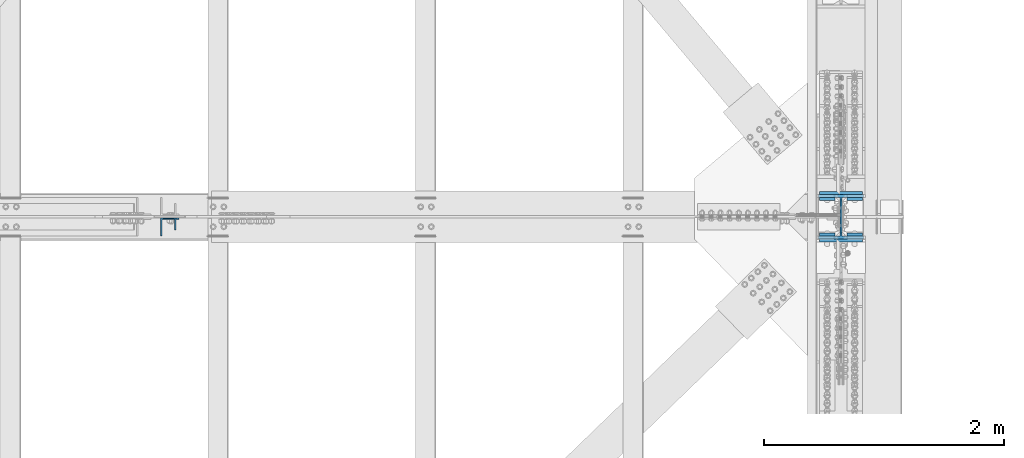
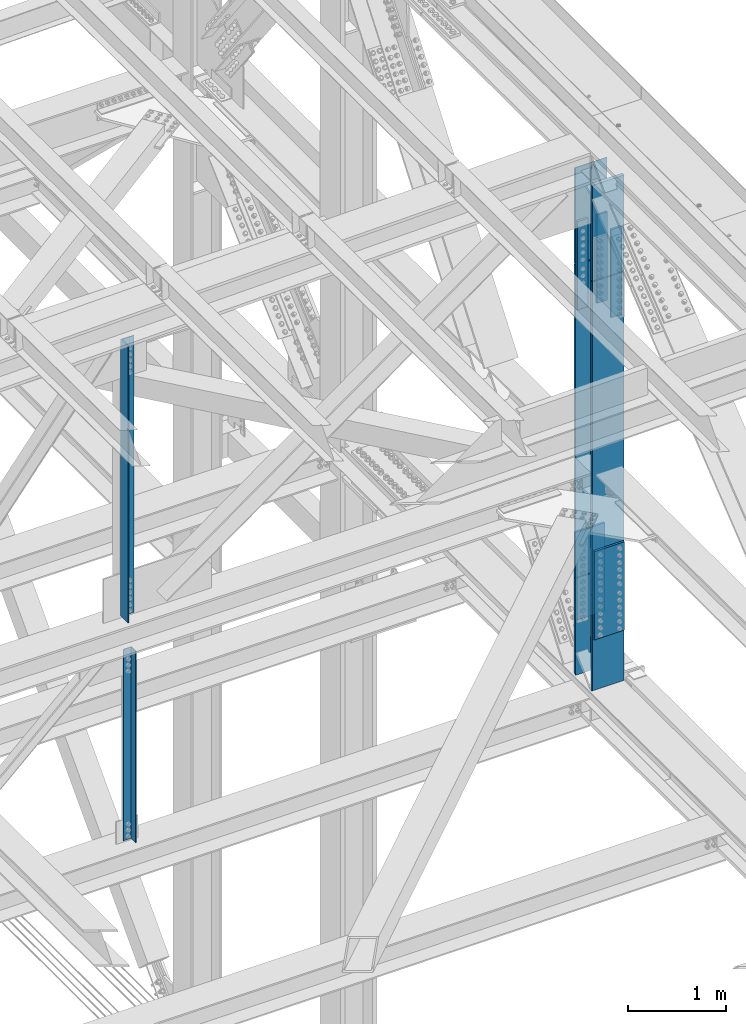
# One storey, part 1421 of 3843: 11 columns, 5 elements without a shape of their own.
"""IFC2X3 building model written with IfcOpenShell, lengths in millimetres."""

from ifc_helpers import new_model, si_unit, frame, origin_with_axes, place, context, subcontext, project, spatial, faceted_brep, material, type_object, element, aggregate, save


model = new_model("IFC2X3")

# Units and contexts
model_context = context("Model", 3, precision=1e-05, world=origin_with_axes())
body_context = subcontext(model_context, "Body", "Model", "MODEL_VIEW")
ifc_project = project(units=[si_unit("LENGTHUNIT", "METRE", prefix="MILLI"), si_unit("AREAUNIT", "SQUARE_METRE"), si_unit("VOLUMEUNIT", "CUBIC_METRE"), si_unit("MASSUNIT", "GRAM", prefix="KILO"), si_unit("TIMEUNIT", "SECOND"), si_unit("PLANEANGLEUNIT", "RADIAN"), si_unit("SOLIDANGLEUNIT", "STERADIAN"), si_unit("THERMODYNAMICTEMPERATUREUNIT", "DEGREE_CELSIUS"), si_unit("LUMINOUSINTENSITYUNIT", "LUMEN")], contexts=[model_context])

# Site, building, storey
site_placement = place(None, origin_with_axes())
site = spatial("IfcSite", under=ifc_project, at=site_placement, CompositionType="ELEMENT")
building_placement = place(site_placement, origin_with_axes())
building = spatial("IfcBuilding", under=site, at=building_placement, Name="Undefined", CompositionType="ELEMENT")
storey_placement = place(building_placement, origin_with_axes())
storey = spatial("IfcBuildingStorey", under=building, at=storey_placement, Name="Undefined", CompositionType="ELEMENT", Elevation=0.0)

# Assembly, column
assembly_1_placement = place(storey_placement, origin_with_axes())
assembly_1 = element("IfcElementAssembly", 1, at=assembly_1_placement, inside=storey, Name="ANGLE", AssemblyPlace="NOTDEFINED", PredefinedType="RIGID_FRAME")
ifc_material_1 = material(Name="STEEL/A572-50")
column_type_1 = type_object("IfcColumnType", Name="L4X4X3/8", PredefinedType="NOTDEFINED")
column_1_placement = place(assembly_1_placement, frame((80060.7999999579, 83924.775, 39453.3460223214), z_axis=(-1.0, 0.0, 0.0), x_axis=(0.0, 0.0, 1.0)))
column_1 = element("IfcColumn", 2, at=column_1_placement, type_object=column_type_1, material=ifc_material_1, Name="ANGLE", ObjectType="L4X4X3/8", context=body_context, shape_type="Brep", body=[
    faceted_brep([(204.712264354988, 50.8000000000029, -50.8000000000029), (204.712264354988, 50.8000000000029, 50.8000000000029), (2598.56616660072, 50.8000000000029, 50.8000000000029), (2598.56616660072, 50.8000000000029, -50.8000000000029), (204.712264354988, 41.2749999999942, 50.8000000000029), (2598.56616660072, 41.2749999999942, 50.8000000000029), (204.712264354988, 41.2749999999942, -41.2749999999942), (2598.56616660072, 41.2749999999942, -41.2749999999942), (204.712264354988, -50.8000000000029, -41.2749999999942), (2598.56616660072, -50.8000000000029, -41.2749999999942), (204.712264354988, -50.8000000000029, -50.8000000000029), (2598.56616660072, -50.8000000000029, -50.8000000000029)], [[[0, 1, 2, 3]], [[1, 4, 5, 2]], [[4, 6, 7, 5]], [[6, 8, 9, 7]], [[8, 10, 11, 9]], [[10, 0, 3, 11]], [[5, 7, 9, 11, 3, 2]], [[10, 8, 6, 4, 1, 0]]]),
])
aggregate(assembly_1, [column_1])

# Assembly, columns
assembly_2_placement = place(storey_placement, origin_with_axes())
assembly_2 = element("IfcElementAssembly", 3, at=assembly_2_placement, inside=storey, Name="BEAM", AssemblyPlace="NOTDEFINED", PredefinedType="RIGID_FRAME")
column_type_2 = type_object("IfcColumnType", PredefinedType="NOTDEFINED")
column_2_placement = place(assembly_2_placement, frame((85534.5, 83837.4625000118, 44292.6980310956), z_axis=(1.0, 0.0, 0.0), x_axis=(0.0, 0.0, 1.0)))
column_2 = element("IfcColumn", 4, at=column_2_placement, type_object=column_type_2, material=ifc_material_1, Name="PLATE", context=body_context, shape_type="Brep", body=[
    faceted_brep([(-4.36557456851006e-11, 12.7000000000116, -63.5), (-4.36557456851006e-11, 12.7000000000116, 63.5), (1104.90000001677, 12.7000000017251, 63.5), (1104.90000001677, 12.7000000017251, -63.5), (1.45519152283669e-11, -12.700000000008, 63.5), (1104.90000001682, -12.6999999982909, 63.5), (1.45519152283669e-11, -12.700000000008, -63.5), (1104.90000001682, -12.6999999982909, -63.5)], [[[0, 1, 2, 3]], [[1, 4, 5, 2]], [[4, 6, 7, 5]], [[6, 0, 3, 7]], [[5, 7, 3, 2]], [[6, 4, 1, 0]]]),
])
column_3_placement = place(assembly_2_placement, frame((85534.5, 84132.7375000003, 44292.6980310956), z_axis=(1.0, 0.0, 0.0), x_axis=(0.0, 0.0, 1.0)))
column_3 = element("IfcColumn", 5, at=column_3_placement, type_object=column_type_2, material=ifc_material_1, Name="PLATE", context=body_context, shape_type="Brep", body=[
    faceted_brep([(-4.36557456851006e-11, 12.7000000000116, -63.5), (-4.36557456851006e-11, 12.7000000000116, 63.5), (1104.90000001677, 12.7000000017251, 63.5), (1104.90000001677, 12.7000000017251, -63.5), (1.45519152283669e-11, -12.700000000008, 63.5), (1104.90000001682, -12.6999999982909, 63.5), (1.45519152283669e-11, -12.700000000008, -63.5), (1104.90000001682, -12.6999999982909, -63.5)], [[[0, 1, 2, 3]], [[1, 4, 5, 2]], [[4, 6, 7, 5]], [[6, 0, 3, 7]], [[5, 7, 3, 2]], [[6, 4, 1, 0]]]),
])
column_4_placement = place(assembly_2_placement, frame((85763.1, 83837.4625000118, 44292.6980310956), z_axis=(1.0, 0.0, 0.0), x_axis=(0.0, 0.0, 1.0)))
column_4 = element("IfcColumn", 6, at=column_4_placement, type_object=column_type_2, material=ifc_material_1, Name="PLATE", context=body_context, shape_type="Brep", body=[
    faceted_brep([(-4.36557456851006e-11, 12.7000000000116, -63.5), (-4.36557456851006e-11, 12.7000000000116, 63.5), (1104.90000001677, 12.7000000017251, 63.5), (1104.90000001677, 12.7000000017251, -63.5), (1.45519152283669e-11, -12.700000000008, 63.5), (1104.90000001682, -12.6999999982909, 63.5), (1.45519152283669e-11, -12.700000000008, -63.5), (1104.90000001682, -12.6999999982909, -63.5)], [[[0, 1, 2, 3]], [[1, 4, 5, 2]], [[4, 6, 7, 5]], [[6, 0, 3, 7]], [[5, 7, 3, 2]], [[6, 4, 1, 0]]]),
])
column_5_placement = place(assembly_2_placement, frame((85763.1, 84132.7375000003, 44292.6980310956), z_axis=(1.0, 0.0, 0.0), x_axis=(0.0, 0.0, 1.0)))
column_5 = element("IfcColumn", 7, at=column_5_placement, type_object=column_type_2, material=ifc_material_1, Name="PLATE", context=body_context, shape_type="Brep", body=[
    faceted_brep([(-4.36557456851006e-11, 12.7000000000116, -63.5), (-4.36557456851006e-11, 12.7000000000116, 63.5), (1104.90000001677, 12.7000000017251, 63.5), (1104.90000001677, 12.7000000017251, -63.5), (1.45519152283669e-11, -12.700000000008, 63.5), (1104.90000001682, -12.6999999982909, 63.5), (1.45519152283669e-11, -12.700000000008, -63.5), (1104.90000001682, -12.6999999982909, -63.5)], [[[0, 1, 2, 3]], [[1, 4, 5, 2]], [[4, 6, 7, 5]], [[6, 0, 3, 7]], [[5, 7, 3, 2]], [[6, 4, 1, 0]]]),
])

# Assembly, column
assembly_3_placement = place(storey_placement, origin_with_axes())
assembly_3 = element("IfcElementAssembly", 8, at=assembly_3_placement, inside=storey, Name="ANGLE", AssemblyPlace="NOTDEFINED", PredefinedType="RIGID_FRAME")
column_type_3 = type_object("IfcColumnType", Name="L6X6X1/2", PredefinedType="NOTDEFINED")
column_6_placement = place(assembly_3_placement, frame((80060.8, 83899.375, 42311.5808310413), z_axis=(0.0, -1.0, 0.0), x_axis=(0.0, 0.0, 1.0)))
column_6 = element("IfcColumn", 9, at=column_6_placement, type_object=column_type_3, material=ifc_material_1, Name="ANGLE", ObjectType="L6X6X1/2", context=body_context, shape_type="Brep", body=[
    faceted_brep([(165.415434551687, 76.1999999999971, -76.1999999999971), (165.415434551687, 76.1999999999971, 76.1999999999971), (3626.66987168015, 76.1999999999971, 76.1999999999971), (3626.66987168015, 76.1999999999971, -76.1999999999971), (165.415434551687, 63.5, 76.1999999999971), (3626.66987168015, 63.5, 76.1999999999971), (165.415434551687, 63.5, -63.5), (3626.66987168015, 63.5, -63.5), (165.415434551687, -76.1999999999971, -63.5), (3626.66987168015, -76.1999999999971, -63.5), (165.415434551687, -76.1999999999971, -76.1999999999971), (3626.66987168015, -76.1999999999971, -76.1999999999971)], [[[0, 1, 2, 3]], [[1, 4, 5, 2]], [[4, 6, 7, 5]], [[6, 8, 9, 7]], [[8, 10, 11, 9]], [[10, 0, 3, 11]], [[5, 7, 9, 11, 3, 2]], [[10, 8, 6, 4, 1, 0]]]),
])
aggregate(assembly_3, [column_6])

# Assembly, columns
assembly_4_placement = place(storey_placement, origin_with_axes())
assembly_4 = element("IfcElementAssembly", 10, at=assembly_4_placement, inside=storey, Name="BEAM", AssemblyPlace="NOTDEFINED", PredefinedType="RIGID_FRAME")
column_type_4 = type_object("IfcColumnType", PredefinedType="NOTDEFINED")
column_7_placement = place(assembly_4_placement, frame((85648.8, 83786.6620684038, 40374.7131606744), z_axis=(-1.0, 0.0, 0.0), x_axis=(0.0, 0.0, 1.0)))
column_7 = element("IfcColumn", 11, at=column_7_placement, type_object=column_type_4, material=ifc_material_1, Name="PLATE", context=body_context, shape_type="Brep", body=[
    faceted_brep([(-1.45519152283669e-11, 12.7000000000025, -177.800000000003), (-1.45519152283669e-11, 12.7000000000025, 177.800000000003), (1104.90000001682, 12.7000000017051, 177.800000000003), (1104.90000001682, 12.7000000017051, -177.800000000003), (4.36557456851006e-11, -12.7000000000171, 177.800000000003), (1104.90000001686, -12.6999999983072, 177.800000000003), (4.36557456851006e-11, -12.7000000000171, -177.800000000003), (1104.90000001686, -12.6999999983072, -177.800000000003)], [[[0, 1, 2, 3]], [[1, 4, 5, 2]], [[4, 6, 7, 5]], [[6, 0, 3, 7]], [[5, 7, 3, 2]], [[6, 4, 1, 0]]]),
])
column_8_placement = place(assembly_4_placement, frame((85648.8, 84183.5375848503, 40374.7131221762), z_axis=(-1.0, 0.0, 0.0), x_axis=(0.0, 0.0, 1.0)))
column_8 = element("IfcColumn", 12, at=column_8_placement, type_object=column_type_4, material=ifc_material_1, Name="PLATE", context=body_context, shape_type="Brep", body=[
    faceted_brep([(-1.45519152283669e-11, 12.7000000000025, -177.800000000003), (-1.45519152283669e-11, 12.7000000000025, 177.800000000003), (1104.90000001682, 12.7000000017051, 177.800000000003), (1104.90000001682, 12.7000000017051, -177.800000000003), (4.36557456851006e-11, -12.7000000000171, 177.800000000003), (1104.90000001686, -12.6999999983072, 177.800000000003), (4.36557456851006e-11, -12.7000000000171, -177.800000000003), (1104.90000001686, -12.6999999983072, -177.800000000003)], [[[0, 1, 2, 3]], [[1, 4, 5, 2]], [[4, 6, 7, 5]], [[6, 0, 3, 7]], [[5, 7, 3, 2]], [[6, 4, 1, 0]]]),
])

# Column
ifc_material_2 = material(Name="STEEL/A992")
column_type_5 = type_object("IfcColumnType", Name="W14X132", PredefinedType="NOTDEFINED")
column_9_placement = place(assembly_2_placement, frame((85648.8, 83985.1000000118, 44845.1480310956), z_axis=(0.0, 1.0, 0.0), x_axis=(0.0, 0.0, 1.0)))
column_9 = element("IfcColumn", 13, at=column_9_placement, type_object=column_type_5, material=ifc_material_2, Name="COLUMN", ObjectType="W14X132", context=body_context, shape_type="Brep", body=[
    faceted_brep([(1203.49614586103, 7.9375, -131.830367742543), (1203.16005296064, 7.9375, 131.820908106049), (1215.47494978287, -4.38226544305508, 131.826701123922), (1215.60898224003, -4.17675526843232, -131.83396684844), (1160.79769559304, -7.9375, -131.817680686072), (1160.79769559304, 7.9375, -131.817680686072), (1215.60898224003, -7.9375, -131.83396684844), (1155.61559319846, -7.9375, -133.34888497577), (1155.61559319846, 7.9375, -133.34888497577), (1152.10036716526, -7.9375, -137.452780410618), (1152.10036716526, 7.9375, -137.452780410618), (1151.38334385253, -7.9375, -142.80858561369), (1151.38334385253, 7.9375, -142.80858561369), (1153.69528719012, -7.9375, -147.692609549733), (1153.69528719012, 7.9375, -147.692609549733), (1165.03467557713, -7.9375, -160.337499999994), (1165.03467557713, 7.9375, -160.337499999994), (1215.64334699394, -7.9375, -160.337499999994), (1215.64334699394, 7.9375, -160.337499999994), (1165.03467557713, 187.324999999997, -160.337499999994), (6.34999999999854, 187.324999999997, -160.337499999994), (6.34999999999854, 7.9375, -160.337499999994), (1215.64334699394, 187.324999999997, -160.337499999994), (6.34999999999854, 7.9375, 160.337499999994), (1164.81580677307, 7.9375, 160.337499999994), (1153.45887069991, 7.9375, 147.676054499054), (1151.14667432922, 7.9375, 142.79162139204), (1151.86398828181, 7.9375, 137.435372748922), (1155.37991423679, 7.9375, 133.331447370423), (1160.56270033512, 7.9375, 131.800869998217), (1153.45887069991, -7.9375, 147.676054499054), (1164.81580677307, -7.9375, 160.337499999994), (1151.14667432922, -7.9375, 142.79162139204), (1151.86398828181, -7.9375, 137.435372748922), (1155.37991423679, -7.9375, 133.331447370423), (1160.56270033512, -7.9375, 131.800869998217), (1215.47494978287, -7.9375, 131.826701123922), (6.34999999999854, -7.9375, 160.337499999994), (6.34999999999854, -7.9375, -160.337499999994), (6.34999999999854, -187.324999999997, -160.337499999994), (1165.03467557713, -187.324999999997, -160.337499999994), (1215.64334699394, -187.324999999997, -160.337499999994), (6.34999999999854, -187.324999999997, -185.737500000003), (6.34999999999854, 187.324999999997, -185.737500000003), (1201.58013327211, 187.324999999997, -185.737500000003), (1201.58013327211, -187.324999999997, -185.737500000003), (1215.64395755383, 187.324999999997, -161.355846424747), (1215.64395755383, -187.324999999997, -161.355846424747), (6.34999999999854, -187.324999999997, 160.337499999994), (6.34999999999854, -187.324999999997, 185.737500000003), (6.34999999999854, 187.324999999997, 185.737500000003), (6.34999999999854, 187.324999999997, 160.337499999994), (1201.29530060472, -187.324999999997, 185.737500000003), (1201.29530060472, 187.324999999997, 185.737500000003), (1215.45017650162, -187.324999999997, 160.974301780676), (1215.45017650162, 187.324999999997, 160.974301780676), (1164.81580677307, 187.324999999997, 160.337499999994), (1215.45051996414, 187.324999999997, 160.337499999994), (1215.45051996414, 7.9375, 160.402995546756), (1215.45051996414, -7.9375, 160.402995546756), (1164.81580677307, -187.324999999997, 160.337499999994), (1215.45051996414, -187.324999999997, 160.337499999994)], [[[0, 1, 2, 3]], [[4, 5, 0, 3, 6]], [[7, 8, 5, 4]], [[9, 10, 8, 7]], [[11, 12, 10, 9]], [[13, 14, 12, 11]], [[15, 16, 14, 13]], [[16, 15, 17, 18]], [[19, 20, 21, 16, 18, 22]], [[0, 5, 8, 10, 12, 14, 16, 21, 23, 24, 25, 26, 27, 28, 29, 1]], [[30, 25, 24, 31]], [[32, 26, 25, 30]], [[33, 27, 26, 32]], [[34, 28, 27, 33]], [[35, 29, 28, 34]], [[1, 29, 35, 36, 2]], [[3, 2, 36, 6]], [[35, 34, 33, 32, 30, 31, 37, 38, 15, 13, 11, 9, 7, 4, 6, 36]], [[15, 38, 39, 40, 41, 17]], [[42, 43, 44, 45]], [[45, 44, 46, 47]], [[40, 39, 42, 45, 47, 41]], [[46, 22, 18, 17, 41, 47]], [[44, 43, 20, 19, 22, 46]], [[42, 39, 38, 37, 48, 49, 50, 51, 23, 21, 20, 43]], [[50, 49, 52, 53]], [[53, 52, 54, 55]], [[56, 51, 50, 53, 55, 57]], [[24, 23, 51, 56, 57, 58]], [[31, 24, 58, 59]], [[60, 48, 37, 31, 59, 61]], [[52, 49, 48, 60, 61, 54]], [[59, 58, 57, 55, 54, 61]]]),
])

aggregate(assembly_2, [column_2, column_3, column_4, column_5, column_9])

# Assembly, column
assembly_5_placement = place(storey_placement, origin_with_axes())
assembly_5 = element("IfcElementAssembly", 14, at=assembly_5_placement, inside=storey, Name="COLUMN", AssemblyPlace="NOTDEFINED", PredefinedType="RIGID_FRAME")
column_10_placement = place(assembly_5_placement, frame((85648.8, 83985.1001383307, 40927.1631414253), z_axis=(0.0, 1.0, 0.0), x_axis=(0.0, 0.0, 1.0)))
column_10 = element("IfcColumn", 15, at=column_10_placement, type_object=column_type_5, material=ifc_material_2, Name="COLUMN", ObjectType="W14X132", context=body_context, shape_type="Brep", body=[
    faceted_brep([(6.34999999999854, 187.324999999997, -185.737500000003), (6.34999999999854, 187.324999999997, -160.337499999994), (3911.6348952821, 187.324999999997, -160.337499989633), (3911.6348961711, 187.324999999997, -185.737499989642), (6.34999999999854, 7.9375, -160.337499999994), (3911.6348952821, 7.9375, -160.337499989633), (6.34999999999854, 7.9375, 160.337499999994), (3911.63488405848, 7.9375, 160.33750001037), (6.34999999999854, 187.324999999997, 160.337499999994), (3911.63488405848, 187.324999999997, 160.33750001037), (6.34999999999854, 187.324999999997, 185.737500000003), (3911.63488316947, 187.324999999997, 185.737500010364), (6.34999999999854, -187.324999999997, 185.737500000003), (3911.63488316947, -187.324999999997, 185.737500010364), (6.34999999999854, -187.324999999997, 160.337499999994), (3911.63488405848, -187.324999999997, 160.33750001037), (6.34999999999854, -7.9375, 160.337499999994), (3911.63488405848, -7.9375, 160.33750001037), (6.34999999999854, -7.9375, -160.337499999994), (3911.6348952821, -7.9375, -160.337499989633), (6.34999999999854, -187.324999999997, -160.337499999994), (3911.6348952821, -187.324999999997, -160.337499989633), (6.34999999999854, -187.324999999997, -185.737500000003), (3911.6348961711, -187.324999999997, -185.737499989642)], [[[0, 1, 2, 3]], [[1, 4, 5, 2]], [[4, 6, 7, 5]], [[6, 8, 9, 7]], [[8, 10, 11, 9]], [[10, 12, 13, 11]], [[12, 14, 15, 13]], [[14, 16, 17, 15]], [[16, 18, 19, 17]], [[18, 20, 21, 19]], [[20, 22, 23, 21]], [[22, 0, 3, 23]], [[5, 7, 9, 11, 13, 15, 17, 19, 21, 23, 3, 2]], [[22, 20, 18, 16, 14, 12, 10, 8, 6, 4, 1, 0]]]),
])
aggregate(assembly_5, [column_10])

# Column
column_11_placement = place(assembly_4_placement, frame((85648.8, 83985.1000000003, 39499.9990183909), z_axis=(0.0, 1.0, 0.0), x_axis=(0.0, 0.0, 1.0)))
column_11 = element("IfcColumn", 16, at=column_11_placement, type_object=column_type_5, material=ifc_material_2, Name="COLUMN", ObjectType="W14X132", context=body_context, shape_type="Brep", body=[
    faceted_brep([(262.384593161485, -7.9375, -131.778796786966), (262.384593161485, 7.9375, -131.778796786966), (267.146500536393, 7.9375, -133.05622686354), (267.146500536393, -7.9375, -133.05622686354), (270.631805376186, 7.9375, -136.543380376286), (270.631805376186, -7.9375, -136.543380376286), (262.387261899108, 7.9375, -160.337499999194), (1420.81412303747, 7.9375, -160.337499995629), (1420.81412303747, 187.324999999997, -160.337499995629), (262.387261899108, 187.324999999997, -160.337499999194), (211.812730802652, 187.324999999997, -160.337499999339), (211.812730802652, 7.9375, -160.337499999339), (261.491226073165, -187.324999999997, 160.337500000809), (1420.81412303748, -187.324999999997, 160.33750000436), (1420.81412303747, -187.324999999997, 185.737500004383), (225.124699107975, -187.324999999997, 185.737500001647), (210.467904951904, -187.324999999997, 160.337500000649), (1420.81412303747, 187.324999999997, 185.737500004383), (225.124699107975, 187.324999999997, 185.737500000701), (1420.81412303748, 187.324999999997, 160.33750000436), (261.491226073165, 187.324999999997, 160.337500000809), (210.467904951904, 187.324999999997, 160.337500000649), (1420.81412303748, 7.9375, 160.33750000436), (261.491226073165, 7.9375, 160.337500000809), (210.467904951904, 7.9375, 160.337500000649), (266.251480493411, -7.9375, 133.038481301512), (266.251480493411, 7.9375, 133.038481301512), (261.489200082389, 7.9375, 131.762499990771), (261.489200082389, -7.9375, 131.762499990771), (269.737838374902, -7.9375, 136.524561010956), (269.737838374902, 7.9375, 136.524561010956), (271.014199672987, -7.9375, 141.286739593837), (271.014199672987, 7.9375, 141.286739593837), (269.738598355376, -7.9375, 146.049121802047), (269.738598355376, 7.9375, 146.049121802047), (261.491226073165, -7.9375, 160.337500000809), (210.467904951904, -7.9375, 160.337500000649), (1420.81412303748, -7.9375, 160.33750000436), (1420.81412303747, -7.9375, -160.337499995629), (1420.81412303747, -187.324999999997, -160.337499995629), (1420.81412303748, -187.324999999997, -185.737499995637), (1420.81412303748, 187.324999999997, -185.737499995637), (262.387261899108, -187.324999999997, -160.337499999194), (262.387261899108, -7.9375, -160.337499999194), (211.812730802652, -7.9375, -160.337499999339), (211.812730802652, -187.324999999997, -160.337499999339), (226.26372923726, -187.324999999997, -185.737500001167), (226.26372923726, 187.324999999997, -185.737499999304), (270.629636963837, -7.9375, -146.067967579525), (270.629636963837, 7.9375, -146.067967579525), (271.90671013543, -7.9375, -141.305964475541), (271.90671013543, 7.9375, -141.305964475541), (227.559844336647, 7.9375, -131.768258331766), (226.461564300829, 7.9375, 131.762499999502), (211.684686453285, -7.9375, -131.763454287357), (210.586426438589, -7.9375, 131.762500003446), (210.587740932518, -7.9375, 131.762500003446), (211.69289892893, -7.9375, -131.763456772576)], [[[0, 1, 2, 3]], [[3, 2, 4, 5]], [[6, 7, 8, 9, 10, 11]], [[12, 13, 14, 15, 16]], [[14, 17, 18, 15]], [[17, 19, 20, 21, 18]], [[20, 19, 22, 23, 24, 21]], [[25, 26, 27, 28]], [[29, 30, 26, 25]], [[31, 32, 30, 29]], [[33, 34, 32, 31]], [[35, 23, 34, 33]], [[23, 35, 36, 24]], [[15, 18, 21, 24, 36, 16]], [[35, 37, 13, 12, 16, 36]], [[7, 22, 19, 17, 14, 13, 37, 38, 39, 40, 41, 8]], [[42, 39, 38, 43, 44, 45]], [[40, 39, 42, 45, 46]], [[41, 40, 46, 47]], [[9, 8, 41, 47, 10]], [[46, 45, 44, 11, 10, 47]], [[43, 6, 11, 44]], [[48, 49, 6, 43]], [[50, 51, 49, 48]], [[5, 4, 51, 50]], [[2, 1, 52, 53, 27, 26, 30, 32, 34, 23, 22, 7, 6, 49, 51, 4]], [[53, 52, 54, 55]], [[28, 27, 53, 55, 56]], [[0, 3, 5, 50, 48, 43, 38, 37, 35, 33, 31, 29, 25, 28, 56, 57]], [[52, 1, 0, 57, 54]], [[56, 55, 54, 57]]]),
])

aggregate(assembly_4, [column_7, column_8, column_11])

save(model, "model.ifc")
